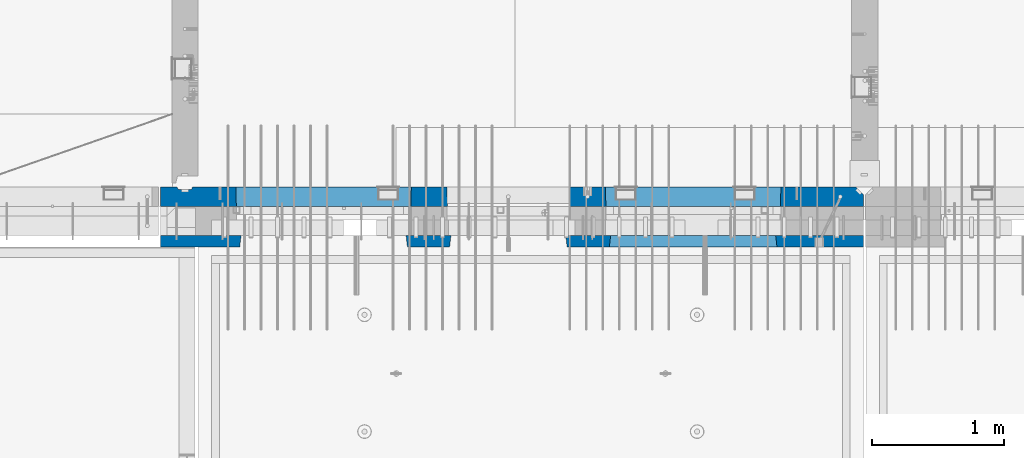
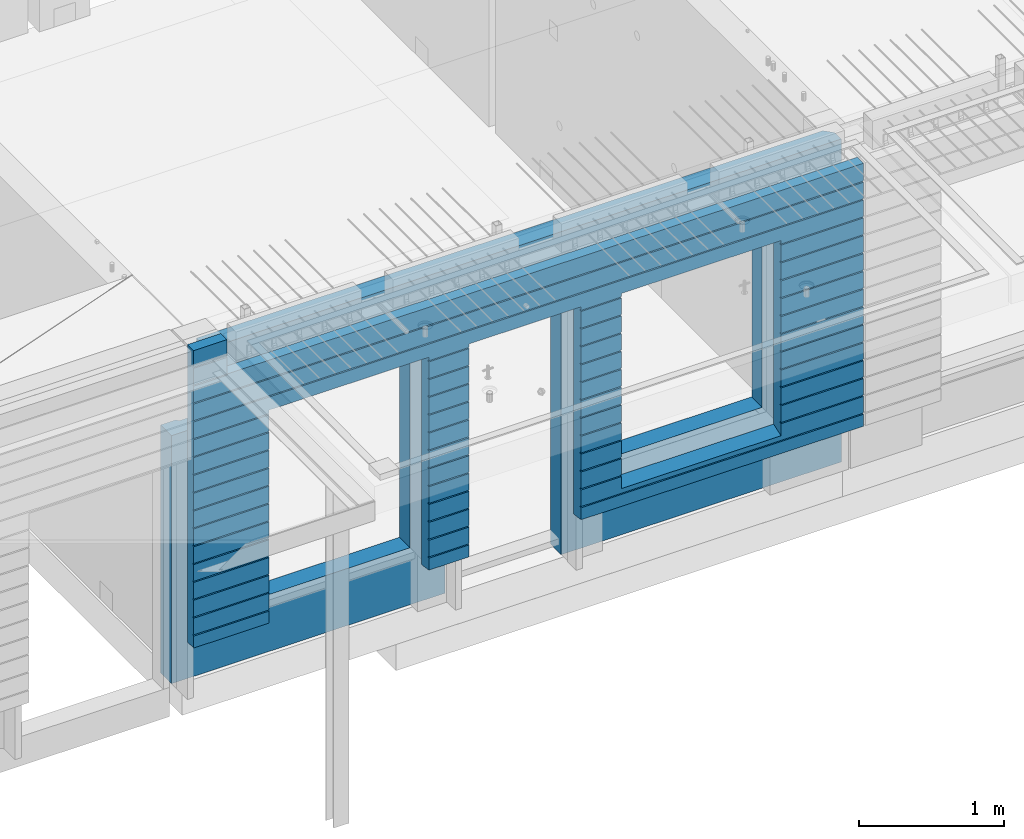
# One storey, part 210 of 325: 2 walls, 1 element without a shape of its own.
"""IFC2X3 building model written with IfcOpenShell, lengths in millimetres."""

from ifc_helpers import new_model, si_unit, frame, origin_with_axes, place, context, subcontext, project, spatial, faceted_brep, material, type_object, element, aggregate, save


model = new_model("IFC2X3")

# Units and contexts
model_context = context("Model", 3, precision=1e-05, world=origin_with_axes())
body_context = subcontext(model_context, "Body", "Model", "MODEL_VIEW")
ifc_project = project(units=[si_unit("LENGTHUNIT", "METRE", prefix="MILLI"), si_unit("AREAUNIT", "SQUARE_METRE"), si_unit("VOLUMEUNIT", "CUBIC_METRE"), si_unit("MASSUNIT", "GRAM", prefix="KILO"), si_unit("TIMEUNIT", "SECOND"), si_unit("PLANEANGLEUNIT", "RADIAN"), si_unit("SOLIDANGLEUNIT", "STERADIAN"), si_unit("THERMODYNAMICTEMPERATUREUNIT", "DEGREE_CELSIUS"), si_unit("LUMINOUSINTENSITYUNIT", "LUMEN")], contexts=[model_context])

# Site, building, storey
site_placement = place(None, origin_with_axes())
site = spatial("IfcSite", under=ifc_project, at=site_placement, CompositionType="ELEMENT")
building_placement = place(site_placement, origin_with_axes())
building = spatial("IfcBuilding", under=site, at=building_placement, CompositionType="ELEMENT")
storey_placement = place(building_placement, origin_with_axes())
storey = spatial("IfcBuildingStorey", under=building, at=storey_placement, Name="1", CompositionType="ELEMENT", Elevation=0.0)

# Assembly, walls
assembly_placement = place(storey_placement, origin_with_axes())
assembly = element("IfcElementAssembly", 1, at=assembly_placement, inside=storey, AssemblyPlace="NOTDEFINED", PredefinedType="REINFORCEMENT_UNIT")
ifc_material_1 = material(Name="CONCRETE/C30/37")
wall_type_1 = type_object("IfcWallType", PredefinedType="NOTDEFINED")
wall_1_placement = place(assembly_placement, frame((21810.0, 7587.5, 83247.5), z_axis=(0.0, 0.0, 1.0), x_axis=(-1.0, 3.00000001838171e-08, 0.0)))
wall_1 = element("IfcWall", 2, at=wall_1_placement, type_object=wall_type_1, material=ifc_material_1, context=body_context, shape_type="Brep", body=[
    faceted_brep([(5070.0, 32.4999992499606, 1344.9999999992), (5335.0, 32.4999992499606, 1344.9999999992), (5335.0, 42.5, 1342.99999994476), (5070.0, 42.5, 1342.99999994476), (5070.0, 32.4999991119566, 1355.00000040043), (5335.0, 32.4999991119566, 1355.00000040043), (5070.0, 42.5, 1356.99999988925), (5335.0, 42.5, 1356.99999988925), (5065.0, 42.4999992673065, 1192.99999994476), (5065.0, 32.4999992499606, 1194.9999999992), (5335.0, 32.4999992499606, 1194.9999999992), (5335.0, 42.5, 1192.99999994476), (5335.0, -42.5, 1492.5), (5335.0, 42.5, 1492.5), (5070.0, 42.5, 1492.5), (5070.0, -42.5, 1492.5), (3144.99845837354, 42.5, -907.000000055225), (3464.99937278789, 42.5, -907.000000055225), (3464.99937278789, 42.5, -1007.5), (3144.99845837354, 42.5, -1007.5), (3466.17584346415, 32.4999992517687, -905.000000000771), (3143.82179161884, 32.4999992517687, -905.000000000771), (3466.17584348039, 32.4999991137711, -894.99999959956), (3143.8217916026, 32.4999991137711, -894.99999959956), (3464.99937278789, 42.5, -893.00000011074), (3144.99845837354, 42.5, -893.00000011074), (3464.99937278789, 42.5, -757.000000055239), (3144.99845837354, 42.5, -757.000000055239), (3466.17584346409, 32.4999992522926, -755.0000000008), (3143.8217916189, 32.4999992522926, -755.0000000008), (3466.17584348032, 32.4999991142913, -744.999999599575), (3143.82179160266, 32.4999991142913, -744.999999599575), (3464.99937278789, 42.5, -743.000000110755), (3144.99845837354, 42.5, -743.000000110755), (3464.99937278789, 42.5, -607.000000055225), (3144.99845837354, 42.5, -607.000000055225), (3466.17584346403, 32.4999992528337, -605.000000000786), (3143.82179161896, 32.4999992528337, -605.000000000786), (3466.17584348026, 32.4999991148306, -594.99999959956), (3143.82179160272, 32.4999991148306, -594.99999959956), (3464.99937278789, 42.5, -593.00000011074), (3144.99845837354, 42.5, -593.00000011074), (3464.99937278789, 42.5, -457.000000055239), (3144.99845837354, 42.5, -457.000000055239), (3466.17584346396, 32.4999992533585, -455.0000000008), (3143.82179161902, 32.4999992533585, -455.0000000008), (3466.1758434802, 32.4999991153554, -444.999999599575), (3143.82179160278, 32.4999991153554, -444.999999599575), (3464.99937278789, 42.5, -443.000000110755), (3144.99845837354, 42.5, -443.000000110755), (3464.99937278789, 42.5, -307.000000055239), (3144.99845837354, 42.5, -307.000000055239), (3466.1758434639, 32.4999992538906, -305.000000000786), (3143.82179161909, 32.4999992538906, -305.000000000786), (3466.17584348014, 32.4999991158948, -294.999999599575), (3143.82179160284, 32.4999991158948, -294.999999599575), (3464.99937278789, 42.5, -293.000000110755), (3144.99845837354, 42.5, -293.000000110755), (3464.99937278789, 42.5, -157.000000055254), (3144.99845837354, 42.5, -157.000000055254), (3466.17584346384, 32.4999992544253, -155.000000000815), (3143.82179161915, 32.4999992544253, -155.000000000815), (3466.17584348008, 32.499999116425, -144.99999959959), (3143.82179160291, 32.499999116425, -144.99999959959), (3464.99937278789, 42.5, -143.000000110769), (3144.99845837354, 42.5, -143.000000110769), (3464.99937278789, 42.5, -7.00000005523907), (3144.99845837354, 42.5, -7.00000005523907), (3466.17584346435, 32.4999992500489, -5.00000000080036), (3143.82179161863, 32.4999992500489, -5.00000000080036), (3466.17584348059, 32.4999991120494, 5.00000040042505), (3143.82179160239, 32.4999991120494, 5.00000040042505), (3464.99937278789, 42.5, 6.99999988924537), (3144.99845837354, 42.5, 6.99999988924537), (3464.99937278789, 42.5, 142.999999944761), (3144.99845837354, 42.5, 142.999999944761), (3466.17584346436, 32.4999992500361, 144.9999999992), (3143.82179161863, 32.4999992500361, 144.9999999992), (3466.17584348059, 32.4999991120385, 155.000000400425), (3143.82179160239, 32.4999991120385, 155.000000400425), (3464.99937278789, 42.5, 156.999999889245), (3144.99845837354, 42.5, 156.999999889245), (3464.99937278789, 42.5, 292.999999944761), (3144.99845837354, 42.5, 292.999999944761), (3466.17584346436, 32.4999992500234, 294.9999999992), (3143.82179161863, 32.4999992500234, 294.9999999992), (3466.17584348059, 32.4999991120249, 305.000000400425), (3143.82179160239, 32.4999991120249, 305.000000400425), (3464.99937278789, 42.5, 306.999999889245), (3144.99845837354, 42.5, 306.999999889245), (3464.99937278789, 42.5, 442.999999944775), (3144.99845837354, 42.5, 442.999999944775), (3466.17584346436, 32.499999250017, 444.999999999229), (3143.82179161863, 32.499999250017, 444.999999999229), (3466.17584348059, 32.4999991120239, 455.000000400454), (3143.82179160239, 32.4999991120239, 455.000000400454), (3464.99937278789, 42.5, 456.99999988926), (3144.99845837354, 42.5, 456.99999988926), (3464.99937278789, 42.5, 592.999999944761), (3144.99845837354, 42.5, 592.999999944761), (3466.17584346436, 32.4999992499943, 594.9999999992), (3143.82179161863, 32.4999992499943, 594.9999999992), (3466.1758434806, 32.4999991119957, 605.000000400425), (3143.82179160239, 32.4999991119957, 605.000000400425), (3464.99937278789, 42.5, 606.999999889245), (3144.99845837354, 42.5, 606.999999889245), (3464.99937278789, 42.5, 742.999999944761), (3144.99845837354, 42.5, 742.999999944761), (3466.17584346436, 32.4999992499852, 744.9999999992), (3143.82179161863, 32.4999992499852, 744.9999999992), (3466.1758434806, 32.4999991119857, 755.000000400425), (3143.82179160239, 32.4999991119857, 755.000000400425), (3464.99937278789, 42.5, 756.999999889245), (3144.99845837354, 42.5, 756.999999889245), (5335.0, 42.5, 756.999999889245), (5335.0, 32.4999991119857, 755.000000400425), (4733.82290209518, 32.4999991119857, 755.000000400425), (4734.99937278789, 42.5, 756.999999889245), (5335.0, 32.4999992499852, 744.9999999992), (4733.82290211142, 32.4999992499852, 744.9999999992), (5335.0, 42.5, 742.999999944761), (4734.99937278789, 42.5, 742.999999944761), (5335.0, 42.5, 606.999999889245), (4734.99937278789, 42.5, 606.999999889245), (5335.0, 32.4999991119957, 605.000000400425), (4733.82290209518, 32.4999991119957, 605.000000400425), (5335.0, 32.4999992499943, 594.9999999992), (4733.82290211142, 32.4999992499943, 594.9999999992), (5335.0, 42.5, 592.999999944761), (4734.99937278789, 42.5, 592.999999944761), (5335.0, 42.5, 456.99999988926), (4734.99937278789, 42.5, 456.99999988926), (5335.0, 32.4999991120239, 455.000000400454), (4733.82290209518, 32.4999991120239, 455.000000400454), (5335.0, 32.499999250017, 444.999999999229), (4733.82290211142, 32.499999250017, 444.999999999229), (5335.0, 42.5, 442.999999944775), (4734.99937278789, 42.5, 442.999999944775), (5335.0, 42.5, 306.999999889245), (4734.99937278789, 42.5, 306.999999889245), (5335.0, 32.4999991120249, 305.000000400425), (4733.82290209518, 32.4999991120249, 305.000000400425), (5335.0, 32.4999992500234, 294.9999999992), (4733.82290211142, 32.4999992500234, 294.9999999992), (5335.0, 42.5, 292.999999944761), (4734.99937278789, 42.5, 292.999999944761), (5335.0, 42.5, 156.999999889245), (4734.99937278789, 42.5, 156.999999889245), (5335.0, 32.4999991120385, 155.000000400425), (4733.82290209518, 32.4999991120385, 155.000000400425), (5335.0, 32.4999992500361, 144.9999999992), (4733.82290211142, 32.4999992500361, 144.9999999992), (5335.0, 42.5, 142.999999944761), (4734.99937278789, 42.5, 142.999999944761), (5335.0, 42.5, 6.99999988924537), (4734.99937278789, 42.5, 6.99999988924537), (5335.0, 32.4999991120494, 5.00000040042505), (4733.82290209519, 32.4999991120494, 5.00000040042505), (5335.0, 32.4999992500489, -5.00000000080036), (4733.82290211142, 32.4999992500489, -5.00000000080036), (5335.0, 42.5, -7.00000005523907), (4734.99937278789, 42.5, -7.00000005523907), (5335.0, 42.5, -143.000000110769), (4734.99937278789, 42.5, -143.000000110769), (5335.0, 32.499999116425, -144.99999959959), (4733.8229020957, 32.499999116425, -144.99999959959), (5335.0, 32.4999992544253, -155.000000000815), (4733.82290211194, 32.4999992544253, -155.000000000815), (5335.0, 42.5, -157.000000055254), (4734.99937278789, 42.5, -157.000000055254), (5335.0, 42.5, -293.000000110755), (4734.99937278789, 42.5, -293.000000110755), (5335.0, 32.4999991158948, -294.999999599575), (4733.82290209564, 32.4999991158948, -294.999999599575), (5335.0, 32.4999992538906, -305.000000000786), (4733.82290211188, 32.4999992538906, -305.000000000786), (5335.0, 42.5, -307.000000055239), (4734.99937278789, 42.5, -307.000000055239), (5335.0, 42.5, -443.000000110755), (4734.99937278789, 42.5, -443.000000110755), (5335.0, 32.4999991153554, -444.999999599575), (4733.82290209558, 32.4999991153554, -444.999999599575), (5335.0, 32.4999992533585, -455.0000000008), (4733.82290211181, 32.4999992533585, -455.0000000008), (5335.0, 42.5, -457.000000055239), (4734.99937278789, 42.5, -457.000000055239), (5335.0, 42.5, -593.00000011074), (4734.99937278789, 42.5, -593.00000011074), (5335.0, 32.4999991148306, -594.99999959956), (4733.82290209552, 32.4999991148306, -594.99999959956), (5335.0, 32.4999992528337, -605.000000000786), (4733.82290211175, 32.4999992528337, -605.000000000786), (5335.0, 42.5, -607.000000055225), (4734.99937278789, 42.5, -607.000000055225), (5335.0, 42.5, -743.000000110755), (4734.99937278789, 42.5, -743.000000110755), (5335.0, 32.4999991142913, -744.999999599575), (4733.82290209545, 32.4999991142913, -744.999999599575), (5335.0, 32.4999992522926, -755.0000000008), (4733.82290211169, 32.4999992522926, -755.0000000008), (5335.0, 42.5, -757.000000055239), (4734.99937278789, 42.5, -757.000000055239), (5335.0, 42.5, -893.00000011074), (4734.99937278789, 42.5, -893.00000011074), (5335.0, 32.4999991137711, -894.99999959956), (4733.82290209539, 32.4999991137711, -894.99999959956), (5335.0, 32.4999992517687, -905.000000000771), (4733.82290211162, 32.4999992517687, -905.000000000771), (5335.0, 42.5, -907.000000055225), (4734.99937278789, 42.5, -907.000000055225), (5335.0, 42.5, -1007.5), (4734.99937278789, 42.5, -1007.5), (5335.0, -42.5, -1007.5), (4724.99937278789, -42.5, -1007.5), (4724.99937278789, -42.5, 782.5), (4724.99937278789, -42.5, 787.5), (4734.99937278789, 42.5, 782.5), (3474.99937278789, 42.5, 782.5), (4724.99937278789, 42.5, 782.5), (3474.99937278789, -42.5, 787.5), (3464.99937278789, 42.5, 782.5), (3474.99937278789, -42.5, 782.5), (3474.99937278789, -42.5, -1007.5), (3134.99679170688, -42.5, -1007.5), (3134.99679170688, -42.5, 782.5), (3134.99679170688, -42.5, 787.502857142856), (3144.99845837354, 42.5, 782.5), (2265.00051719707, 42.5, 782.5), (3135.00051719707, 42.5, 782.5), (2265.00012504021, -42.5, 787.502857142856), (2254.99845837354, 42.5, 782.5), (10.0, 42.5, 1056.99999988925), (5335.0, 42.5, 1056.99999988925), (5335.0, 32.4999991119648, 1055.00000040043), (10.0, 32.4999991119648, 1055.00000040043), (5335.0, 32.4999992499625, 1044.9999999992), (10.0, 32.4999992499625, 1044.9999999992), (5335.0, 42.5, 1042.99999994476), (10.0, 42.5, 1042.99999994476), (5335.0, 42.5, 906.999999889245), (10.0, 42.5, 906.999999889245), (5335.0, 32.4999991119739, 905.000000400425), (10.0000008873085, 32.4999991121613, 905.000000400425), (5335.0, 32.4999992499725, 894.9999999992), (10.0000007493072, 32.4999992501671, 894.999999999214), (5335.0, 42.5, 892.999999944761), (10.0, 42.5, 892.999999944761), (10.0, 32.4999992499852, 744.9999999992), (10.0, 32.4999991119857, 755.000000400425), (666.176606420049, 32.4999991119857, 755.000000400425), (666.176606403813, 32.4999992499852, 744.9999999992), (10.0, 42.5, 742.999999944761), (665.00013572734, 42.5, 742.999999944761), (10.0, 42.5, 606.999999889245), (665.00013572734, 42.5, 606.999999889245), (10.0000008873085, 32.4999991121613, 605.000000400425), (666.176606420049, 32.4999991119957, 605.000000400425), (10.0000007493072, 32.4999992501671, 594.999999999214), (666.176606403813, 32.4999992499943, 594.9999999992), (10.0, 42.5, 592.999999944761), (665.00013572734, 42.5, 592.999999944761), (10.0, 42.5, 456.99999988926), (665.00013572734, 42.5, 456.99999988926), (10.0, 32.4999991120239, 455.000000400454), (666.176606420046, 32.4999991120239, 455.000000400454), (10.0, 32.499999250017, 444.999999999229), (666.176606403809, 32.499999250017, 444.999999999229), (10.0, 42.5, 442.999999944775), (665.00013572734, 42.5, 442.999999944775), (10.0, 42.5, 306.999999889245), (665.00013572734, 42.5, 306.999999889245), (10.0000008873085, 32.4999991121613, 305.000000400425), (666.176606420046, 32.4999991120249, 305.000000400425), (10.0000007493072, 32.4999992501671, 294.999999999214), (666.176606403809, 32.4999992500234, 294.9999999992), (10.0, 42.5, 292.999999944761), (665.00013572734, 42.5, 292.999999944761), (10.0, 42.5, 156.999999889245), (665.00013572734, 42.5, 156.999999889245), (10.0, 32.4999991120385, 155.000000400425), (666.176606420046, 32.4999991120385, 155.000000400425), (10.0, 32.4999992500361, 144.9999999992), (666.176606403809, 32.4999992500361, 144.9999999992), (10.0, 42.5, 142.999999944761), (665.00013572734, 42.5, 142.999999944761), (10.0, 42.5, 6.99999988924537), (665.00013572734, 42.5, 6.99999988924537), (10.0, 32.4999991120494, 5.00000040042505), (666.176606420042, 32.4999991120494, 5.00000040042505), (10.0, 32.4999992500489, -5.00000000080036), (666.176606403806, 32.4999992500489, -5.00000000080036), (10.0, 42.5, -7.00000005523907), (665.00013572734, 42.5, -7.00000005523907), (10.0, 42.5, -143.000000110769), (665.00013572734, 42.5, -143.000000110769), (10.0, 32.499999116425, -144.99999959959), (666.176606419529, 32.499999116425, -144.99999959959), (10.0, 32.4999992544253, -155.000000000815), (666.176606403293, 32.4999992544253, -155.000000000815), (10.0, 42.5, -157.000000055254), (665.00013572734, 42.5, -157.000000055254), (10.0, 42.5, -293.000000110755), (665.00013572734, 42.5, -293.000000110755), (10.0000008873085, 32.4999991121613, -294.999999599575), (666.176606419591, 32.4999991158948, -294.999999599575), (10.0000007493072, 32.4999992501671, -305.000000000786), (666.176606403355, 32.4999992538906, -305.000000000786), (10.0, 42.5, -307.000000055239), (665.00013572734, 42.5, -307.000000055239), (10.0, 42.5, -443.000000110755), (665.00013572734, 42.5, -443.000000110755), (10.0, 32.4999991153554, -444.999999599575), (666.176606419653, 32.4999991153554, -444.999999599575), (10.0, 32.4999992533585, -455.0000000008), (666.17660640342, 32.4999992533585, -455.0000000008), (10.0, 42.5, -457.000000055239), (665.00013572734, 42.5, -457.000000055239), (10.0, 42.5, -593.00000011074), (665.00013572734, 42.5, -593.00000011074), (10.0000008873085, 32.4999991121613, -594.999999599575), (666.176606419715, 32.4999991148306, -594.99999959956), (10.0000007493072, 32.4999992501671, -605.000000000786), (666.176606403482, 32.4999992528337, -605.000000000786), (10.0, 42.5, -607.000000055225), (665.00013572734, 42.5, -607.000000055225), (10.0, 42.5, -743.000000110755), (665.00013572734, 42.5, -743.000000110755), (10.0, 32.4999991142913, -744.999999599575), (666.176606419776, 32.4999991142913, -744.999999599575), (10.0, 32.4999992522926, -755.0000000008), (666.176606403544, 32.4999992522926, -755.0000000008), (10.0, 42.5, -757.000000055239), (665.00013572734, 42.5, -757.000000055239), (665.00013572734, 42.5, -857.5), (675.00013572734, -42.5, -807.5), (1925.00013572734, -42.5, -807.5), (1935.00013572734, 42.5, -857.5), (1925.00013572734, -42.5, 782.5), (1925.00013572734, -42.5, 787.5), (1935.00013572734, 42.5, 782.5), (1935.00013572734, 42.5, 756.999999889245), (1933.82366503463, 32.4999991119857, 755.000000400425), (1933.82366505087, 32.4999992499852, 744.9999999992), (1935.00013572734, 42.5, 742.999999944761), (1935.00013572734, 42.5, 606.999999889245), (1933.82366503463, 32.4999991119957, 605.000000400425), (1933.82366505087, 32.4999992499943, 594.9999999992), (1935.00013572734, 42.5, 592.999999944761), (1935.00013572734, 42.5, 456.99999988926), (1933.82366503464, 32.4999991120239, 455.000000400454), (1933.82366505087, 32.499999250017, 444.999999999229), (1935.00013572734, 42.5, 442.999999944775), (1935.00013572734, 42.5, 306.999999889245), (1933.82366503464, 32.4999991120249, 305.000000400425), (1933.82366505087, 32.4999992500234, 294.9999999992), (1935.00013572734, 42.5, 292.999999944761), (1935.00013572734, 42.5, 156.999999889245), (1933.82366503464, 32.4999991120385, 155.000000400425), (1933.82366505087, 32.4999992500361, 144.9999999992), (1935.00013572734, 42.5, 142.999999944761), (1935.00013572734, 42.5, 6.99999988924537), (1933.82366503464, 32.4999991120494, 5.00000040042505), (1933.82366505088, 32.4999992500489, -5.00000000080036), (1935.00013572734, 42.5, -7.00000005523907), (1935.00013572734, 42.5, -143.000000110769), (1933.82366503515, 32.499999116425, -144.99999959959), (1933.82366505139, 32.4999992544253, -155.000000000815), (1935.00013572734, 42.5, -157.000000055254), (1935.00013572734, 42.5, -293.000000110755), (1933.82366503509, 32.4999991158948, -294.999999599575), (1933.82366505132, 32.4999992538906, -305.000000000786), (1935.00013572734, 42.5, -307.000000055239), (1935.00013572734, 42.5, -443.000000110755), (1933.82366503503, 32.4999991153554, -444.999999599575), (1933.82366505126, 32.4999992533585, -455.0000000008), (1935.00013572734, 42.5, -457.000000055239), (1935.00013572734, 42.5, -593.00000011074), (1933.82366503496, 32.4999991148306, -594.99999959956), (1933.8236650512, 32.4999992528337, -605.000000000786), (1935.00013572734, 42.5, -607.000000055225), (1935.00013572734, 42.5, -743.000000110755), (1933.8236650349, 32.4999991142913, -744.999999599575), (1933.82366505114, 32.4999992522926, -755.0000000008), (1935.00013572734, 42.5, -757.000000055239), (2254.99845837354, 42.5, 756.999999889245), (2256.17512514469, 32.4999991119857, 755.000000400425), (2256.17512512846, 32.4999992499852, 744.9999999992), (2254.99845837354, 42.5, 742.999999944761), (2254.99845837354, 42.5, 606.999999889245), (2256.17512514469, 32.4999991119957, 605.000000400425), (2256.17512512846, 32.4999992499943, 594.9999999992), (2254.99845837354, 42.5, 592.999999944761), (2254.99845837354, 42.5, 456.99999988926), (2256.17512514469, 32.4999991120239, 455.000000400454), (2256.17512512846, 32.499999250017, 444.999999999229), (2254.99845837354, 42.5, 442.999999944775), (2254.99845837354, 42.5, 306.999999889245), (2256.17512514469, 32.4999991120249, 305.000000400425), (2256.17512512846, 32.4999992500234, 294.9999999992), (2254.99845837354, 42.5, 292.999999944761), (2254.99845837354, 42.5, 156.999999889245), (2256.17512514469, 32.4999991120385, 155.000000400425), (2256.17512512846, 32.4999992500361, 144.9999999992), (2254.99845837354, 42.5, 142.999999944761), (2254.99845837354, 42.5, 6.99999988924537), (2256.17512514469, 32.4999991120494, 5.00000040042505), (2256.17512512846, 32.4999992500489, -5.00000000080036), (2254.99845837354, 42.5, -7.00000005523907), (2254.99845837354, 42.5, -143.000000110769), (2256.17512514417, 32.499999116425, -144.99999959959), (2256.17512512794, 32.4999992544253, -155.000000000815), (2254.99845837354, 42.5, -157.000000055254), (2254.99845837354, 42.5, -293.000000110755), (2256.17512514424, 32.4999991158948, -294.999999599575), (2256.175125128, 32.4999992538906, -305.000000000786), (2254.99845837354, 42.5, -307.000000055239), (2254.99845837354, 42.5, -443.000000110755), (2256.1751251443, 32.4999991153554, -444.999999599575), (2256.17512512806, 32.4999992533585, -455.0000000008), (2254.99845837354, 42.5, -457.000000055239), (2254.99845837354, 42.5, -593.00000011074), (2256.17512514436, 32.4999991148306, -594.99999959956), (2256.17512512813, 32.4999992528337, -605.000000000786), (2254.99845837354, 42.5, -607.000000055225), (2254.99845837354, 42.5, -743.000000110755), (2256.17512514443, 32.4999991142913, -744.999999599575), (2256.17512512819, 32.4999992522926, -755.0000000008), (2254.99845837354, 42.5, -757.000000055239), (10.0, 42.5, -893.00000011074), (2254.99845837354, 42.5, -893.00000011074), (10.0000008873085, 32.4999991121613, -894.999999599575), (2256.17512514449, 32.4999991137711, -894.99999959956), (10.0000007493072, 32.4999992501671, -905.000000000786), (2256.17512512825, 32.4999992517687, -905.000000000771), (10.0, 42.5, -907.000000055225), (2254.99845837354, 42.5, -907.000000055225), (2254.99845837354, 42.5, -1007.5), (10.0, 42.5, -1007.5), (10.0, 42.5, 756.999999889245), (10.0, -42.5, -1007.5), (10.0, -42.5, 1202.5), (10.0, 42.5, 1202.5), (2265.00012504021, -42.5, -1007.5), (2265.00012504021, -42.5, 782.5), (1925.00013572734, 42.5, 782.5), (675.00013572734, 42.5, 782.5), (665.00013572734, 42.5, 782.5), (665.00013572734, 42.5, 756.999999889245), (675.00013572734, -42.5, 787.5), (675.00013572734, -42.5, 782.5), (5070.0, -42.5, 1202.5), (5070.0, 32.4999991464583, 1202.5), (5065.0, 32.4999991464574, 1202.5), (5065.0, 42.5, 1202.5), (5070.0, 32.4999991119566, 1205.00000040043), (5335.0, 32.4999991119566, 1205.00000040043), (5070.0, 42.5, 1206.99999988925), (5335.0, 42.5, 1206.99999988925)], [[[0, 1, 2, 3]], [[4, 5, 1, 0]], [[6, 7, 5, 4]], [[8, 9, 10, 11]], [[12, 13, 14, 15]], [[16, 17, 18, 19]], [[20, 17, 16, 21]], [[22, 20, 21, 23]], [[24, 22, 23, 25]], [[26, 24, 25, 27]], [[28, 26, 27, 29]], [[30, 28, 29, 31]], [[32, 30, 31, 33]], [[34, 32, 33, 35]], [[36, 34, 35, 37]], [[38, 36, 37, 39]], [[40, 38, 39, 41]], [[42, 40, 41, 43]], [[44, 42, 43, 45]], [[46, 44, 45, 47]], [[48, 46, 47, 49]], [[50, 48, 49, 51]], [[52, 50, 51, 53]], [[54, 52, 53, 55]], [[56, 54, 55, 57]], [[58, 56, 57, 59]], [[60, 58, 59, 61]], [[62, 60, 61, 63]], [[64, 62, 63, 65]], [[66, 64, 65, 67]], [[68, 66, 67, 69]], [[70, 68, 69, 71]], [[72, 70, 71, 73]], [[74, 72, 73, 75]], [[76, 74, 75, 77]], [[78, 76, 77, 79]], [[80, 78, 79, 81]], [[82, 80, 81, 83]], [[84, 82, 83, 85]], [[86, 84, 85, 87]], [[88, 86, 87, 89]], [[90, 88, 89, 91]], [[92, 90, 91, 93]], [[94, 92, 93, 95]], [[96, 94, 95, 97]], [[98, 96, 97, 99]], [[100, 98, 99, 101]], [[102, 100, 101, 103]], [[104, 102, 103, 105]], [[106, 104, 105, 107]], [[108, 106, 107, 109]], [[110, 108, 109, 111]], [[112, 110, 111, 113]], [[114, 115, 116, 117]], [[115, 118, 119, 116]], [[118, 120, 121, 119]], [[120, 122, 123, 121]], [[122, 124, 125, 123]], [[124, 126, 127, 125]], [[126, 128, 129, 127]], [[128, 130, 131, 129]], [[130, 132, 133, 131]], [[132, 134, 135, 133]], [[134, 136, 137, 135]], [[136, 138, 139, 137]], [[138, 140, 141, 139]], [[140, 142, 143, 141]], [[142, 144, 145, 143]], [[144, 146, 147, 145]], [[146, 148, 149, 147]], [[148, 150, 151, 149]], [[150, 152, 153, 151]], [[152, 154, 155, 153]], [[154, 156, 157, 155]], [[156, 158, 159, 157]], [[158, 160, 161, 159]], [[160, 162, 163, 161]], [[162, 164, 165, 163]], [[164, 166, 167, 165]], [[166, 168, 169, 167]], [[168, 170, 171, 169]], [[170, 172, 173, 171]], [[172, 174, 175, 173]], [[174, 176, 177, 175]], [[176, 178, 179, 177]], [[178, 180, 181, 179]], [[180, 182, 183, 181]], [[182, 184, 185, 183]], [[184, 186, 187, 185]], [[186, 188, 189, 187]], [[188, 190, 191, 189]], [[190, 192, 193, 191]], [[192, 194, 195, 193]], [[194, 196, 197, 195]], [[196, 198, 199, 197]], [[198, 200, 201, 199]], [[200, 202, 203, 201]], [[202, 204, 205, 203]], [[204, 206, 207, 205]], [[206, 208, 209, 207]], [[209, 208, 210, 211]], [[210, 212, 213, 211]], [[214, 215, 216, 117, 116, 119, 121, 123, 125, 127, 129, 131, 133, 135, 137, 139, 141, 143, 145, 147, 149, 151, 153, 155, 157, 159, 161, 163, 165, 167, 169, 171, 173, 175, 177, 179, 181, 183, 185, 187, 189, 191, 193, 195, 197, 199, 201, 203, 205, 207, 209, 211, 213]], [[217, 218, 216, 215, 219, 220]], [[17, 20, 22, 24, 26, 28, 30, 32, 34, 36, 38, 40, 42, 44, 46, 48, 50, 52, 54, 56, 58, 60, 62, 64, 66, 68, 70, 72, 74, 76, 78, 80, 82, 84, 86, 88, 90, 92, 94, 96, 98, 100, 102, 104, 106, 108, 110, 112, 220, 219, 221, 222, 18]], [[18, 222, 223, 19]], [[224, 225, 226, 113, 111, 109, 107, 105, 103, 101, 99, 97, 95, 93, 91, 89, 87, 85, 83, 81, 79, 77, 75, 73, 71, 69, 67, 65, 63, 61, 59, 57, 55, 53, 51, 49, 47, 45, 43, 41, 39, 37, 35, 33, 31, 29, 27, 25, 23, 21, 16, 19, 223]], [[227, 228, 226, 225, 229, 230]], [[231, 232, 233, 234]], [[234, 233, 235, 236]], [[236, 235, 237, 238]], [[239, 240, 238, 237]], [[240, 239, 241, 242]], [[242, 241, 243, 244]], [[244, 243, 245, 246]], [[247, 248, 249, 250]], [[251, 247, 250, 252]], [[253, 251, 252, 254]], [[255, 253, 254, 256]], [[257, 255, 256, 258]], [[259, 257, 258, 260]], [[261, 259, 260, 262]], [[263, 261, 262, 264]], [[265, 263, 264, 266]], [[267, 265, 266, 268]], [[269, 267, 268, 270]], [[271, 269, 270, 272]], [[273, 271, 272, 274]], [[275, 273, 274, 276]], [[277, 275, 276, 278]], [[279, 277, 278, 280]], [[281, 279, 280, 282]], [[283, 281, 282, 284]], [[285, 283, 284, 286]], [[287, 285, 286, 288]], [[289, 287, 288, 290]], [[291, 289, 290, 292]], [[293, 291, 292, 294]], [[295, 293, 294, 296]], [[297, 295, 296, 298]], [[299, 297, 298, 300]], [[301, 299, 300, 302]], [[303, 301, 302, 304]], [[305, 303, 304, 306]], [[307, 305, 306, 308]], [[309, 307, 308, 310]], [[311, 309, 310, 312]], [[313, 311, 312, 314]], [[315, 313, 314, 316]], [[317, 315, 316, 318]], [[319, 317, 318, 320]], [[321, 319, 320, 322]], [[323, 321, 322, 324]], [[325, 323, 324, 326]], [[327, 325, 326, 328]], [[329, 327, 328, 330]], [[331, 329, 330, 332]], [[333, 334, 335, 336]], [[337, 338, 339, 340, 341, 342, 343, 344, 345, 346, 347, 348, 349, 350, 351, 352, 353, 354, 355, 356, 357, 358, 359, 360, 361, 362, 363, 364, 365, 366, 367, 368, 369, 370, 371, 372, 373, 374, 375, 376, 377, 378, 379, 380, 381, 382, 383, 336, 335]], [[341, 340, 384, 385]], [[342, 341, 385, 386]], [[343, 342, 386, 387]], [[344, 343, 387, 388]], [[345, 344, 388, 389]], [[346, 345, 389, 390]], [[347, 346, 390, 391]], [[348, 347, 391, 392]], [[349, 348, 392, 393]], [[350, 349, 393, 394]], [[351, 350, 394, 395]], [[352, 351, 395, 396]], [[353, 352, 396, 397]], [[354, 353, 397, 398]], [[355, 354, 398, 399]], [[356, 355, 399, 400]], [[357, 356, 400, 401]], [[358, 357, 401, 402]], [[359, 358, 402, 403]], [[360, 359, 403, 404]], [[361, 360, 404, 405]], [[362, 361, 405, 406]], [[363, 362, 406, 407]], [[364, 363, 407, 408]], [[365, 364, 408, 409]], [[366, 365, 409, 410]], [[367, 366, 410, 411]], [[368, 367, 411, 412]], [[369, 368, 412, 413]], [[370, 369, 413, 414]], [[371, 370, 414, 415]], [[372, 371, 415, 416]], [[373, 372, 416, 417]], [[374, 373, 417, 418]], [[375, 374, 418, 419]], [[376, 375, 419, 420]], [[377, 376, 420, 421]], [[378, 377, 421, 422]], [[379, 378, 422, 423]], [[380, 379, 423, 424]], [[381, 380, 424, 425]], [[382, 381, 425, 426]], [[383, 382, 426, 427]], [[428, 331, 332, 333, 336, 383, 427, 429]], [[430, 428, 429, 431]], [[432, 430, 431, 433]], [[434, 432, 433, 435]], [[434, 435, 436, 437]], [[231, 234, 236, 238, 240, 242, 244, 246, 438, 248, 247, 251, 253, 255, 257, 259, 261, 263, 265, 267, 269, 271, 273, 275, 277, 279, 281, 283, 285, 287, 289, 291, 293, 295, 297, 299, 301, 303, 305, 307, 309, 311, 313, 315, 317, 319, 321, 323, 325, 327, 329, 331, 428, 430, 432, 434, 437, 439, 440, 441]], [[436, 442, 439, 437]], [[435, 433, 431, 429, 427, 426, 425, 424, 423, 422, 421, 420, 419, 418, 417, 416, 415, 414, 413, 412, 411, 410, 409, 408, 407, 406, 405, 404, 403, 402, 401, 400, 399, 398, 397, 396, 395, 394, 393, 392, 391, 390, 389, 388, 387, 386, 385, 384, 230, 229, 443, 442, 436]], [[340, 339, 444, 445, 446, 447, 438, 246, 245, 114, 117, 216, 218, 217, 220, 112, 113, 226, 228, 227, 230, 384]], [[248, 438, 447, 249]], [[446, 448, 449, 334, 333, 332, 330, 328, 326, 324, 322, 320, 318, 316, 314, 312, 310, 308, 306, 304, 302, 300, 298, 296, 294, 292, 290, 288, 286, 284, 282, 280, 278, 276, 274, 272, 270, 268, 266, 264, 262, 260, 258, 256, 254, 252, 250, 249, 447]], [[445, 444, 339, 338, 448, 446]], [[439, 442, 443, 229, 225, 224, 223, 222, 221, 219, 215, 214, 213, 212, 12, 15, 450, 440], [337, 335, 334, 449, 448, 338]], [[441, 440, 450, 451, 452, 453]], [[11, 232, 231, 441, 453, 8]], [[452, 9, 8, 453]], [[451, 454, 455, 10, 9, 452]], [[456, 457, 455, 454]], [[457, 456, 3, 2]], [[13, 12, 212, 210, 208, 206, 204, 202, 200, 198, 196, 194, 192, 190, 188, 186, 184, 182, 180, 178, 176, 174, 172, 170, 168, 166, 164, 162, 160, 158, 156, 154, 152, 150, 148, 146, 144, 142, 140, 138, 136, 134, 132, 130, 128, 126, 124, 122, 120, 118, 115, 114, 245, 243, 241, 239, 237, 235, 233, 232, 11, 10, 455, 457, 2, 1, 5, 7]], [[14, 13, 7, 6]], [[3, 456, 454, 451, 450, 15, 14, 6, 4, 0]]]),
])
ifc_material_2 = material(Name="CONCRETE/C35/45")
wall_type_2 = type_object("IfcWallType", PredefinedType="NOTDEFINED")
wall_2_placement = place(assembly_placement, frame((21810.0, 7925.0, 83112.5), z_axis=(0.0, 0.0, 1.0), x_axis=(-1.0, 3.00000001838171e-08, 0.0)))
wall_2 = element("IfcWall", 3, at=wall_2_placement, type_object=wall_type_2, material=ifc_material_2, context=body_context, shape_type="Brep", body=[
    faceted_brep([(5092.99999918154, -74.9999956538213, 727.503662109375), (5100.00000194586, -55.0000074740619, 727.503662109375), (5199.99999958945, -55.0000061443834, 727.503662109375), (5213.0, -75.0, 727.503662109375), (5335.0, -75.0, 727.503662109375), (5335.0, 75.0, 727.503662109375), (5050.0, 75.0, 727.503662109375), (5050.0, -74.9999966562636, 727.503662109375), (5050.0, -74.9999943890452, 1357.5), (5050.0, 75.0, 1357.5), (10.0, 75.0, 1357.5), (10.0, 75.0, -1357.5), (10.0, -15.0, -1357.5), (10.0, -15.0, 1357.5), (5335.0, -75.0, -1357.5), (5335.0, 75.0, -1357.5), (5213.0, -75.0, -1357.5), (5199.99999958945, -55.0000061443834, -1357.5), (5100.00000194586, -55.0000074740619, -1357.5), (5092.99999918154, -75.0, -1357.5), (3165.00051719707, -75.0, -1357.5), (3161.15436335092, 75.0, -1357.5), (3165.00051719707, -75.0, 952.5), (3161.15436335092, 75.0, 948.653846153844), (2235.00051719707, -75.0, 952.5), (2238.84667104322, 75.0, 948.653846153844), (2235.00051719707, -75.0, -1357.5), (2238.84667104322, 75.0, -1357.5), (70.0, -75.0, -1357.5), (70.0, -75.0, 1357.5), (4764.99937278789, -75.0, -882.5), (4760.94531873383, 75.0, -878.445945945947), (3439.05342684194, 75.0, -878.445945945947), (3434.99937278789, -75.0, -882.5), (4764.99937278789, -75.0, 952.5), (4760.94531873383, 75.0, 948.445945945947), (3434.99937278789, -75.0, 952.5), (3439.05342684194, 75.0, 948.445945945947), (1960.94608167329, 75.0, -678.445945945947), (1960.94608167329, 75.0, 948.445945945947), (639.054189781393, 75.0, 948.445945945947), (639.054189781393, 75.0, -678.445945945947), (635.00013572734, -75.0, -682.5), (635.00013572734, -75.0, 952.5), (1965.00013572734, -75.0, -682.5), (1965.00013572734, -75.0, 952.5)], [[[0, 1, 2, 3, 4, 5, 6, 7]], [[8, 7, 6, 9]], [[10, 11, 12, 13]], [[14, 15, 5, 4]], [[16, 14, 4, 3]], [[17, 16, 3, 2]], [[18, 17, 2, 1]], [[19, 18, 1, 0]], [[20, 21, 15, 14, 16, 17, 18, 19]], [[21, 20, 22, 23]], [[24, 25, 23, 22]], [[26, 27, 25, 24]], [[28, 12, 11, 27, 26]], [[13, 12, 28, 29]], [[10, 13, 29, 8, 9]], [[30, 31, 32, 33]], [[31, 30, 34, 35]], [[36, 37, 35, 34]], [[33, 32, 37, 36]], [[5, 15, 21, 23, 25, 27, 11, 10, 9, 6], [31, 35, 37, 32], [38, 39, 40, 41]], [[42, 41, 40, 43]], [[44, 38, 41, 42]], [[38, 44, 45, 39]], [[43, 40, 39, 45]], [[29, 28, 26, 24, 22, 20, 19, 0, 7, 8], [44, 42, 43, 45], [30, 33, 36, 34]]]),
])
aggregate(assembly, [wall_1, wall_2])

save(model, "model.ifc")
